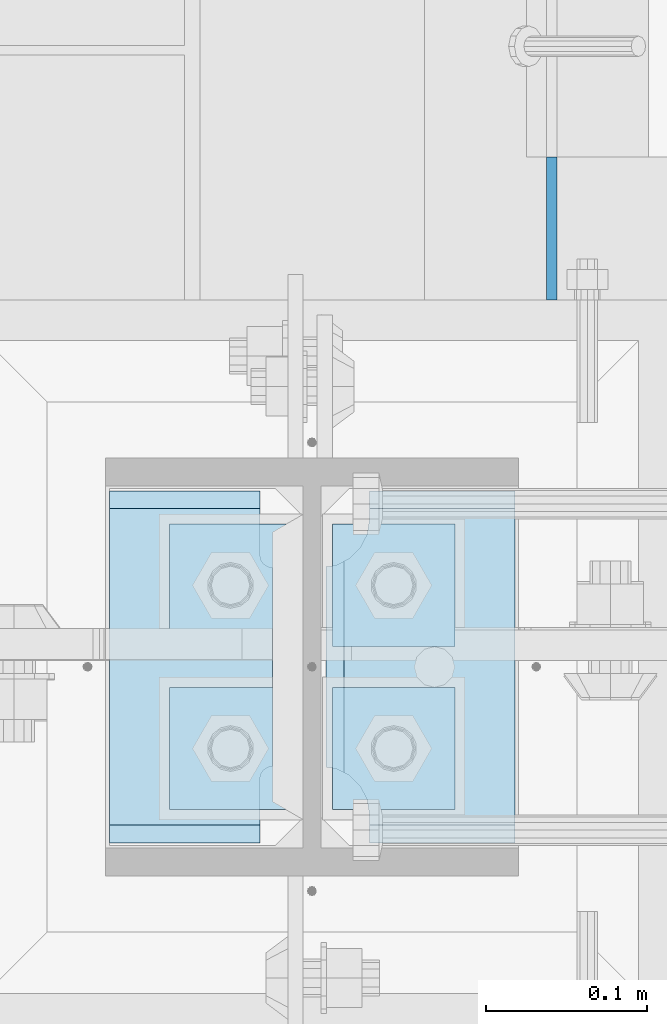
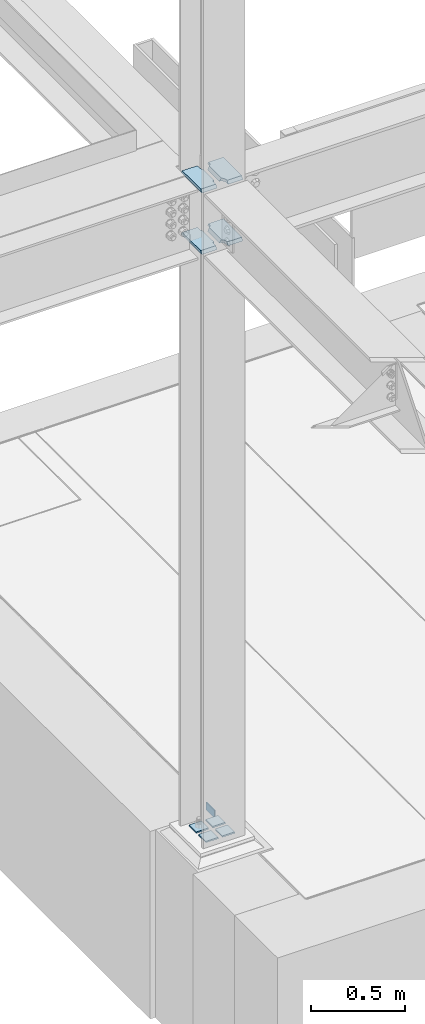
# One storey, part 3058 of 3843: 9 plates, 3 elements without a shape of their own.
"""IFC2X3 building model written with IfcOpenShell, lengths in millimetres."""

from ifc_helpers import new_model, si_unit, frame, origin_with_axes, place, context, subcontext, project, spatial, faceted_brep, material, type_object, element, aggregate, save


model = new_model("IFC2X3")

# Units and contexts
model_context = context("Model", 3, precision=1e-05, world=origin_with_axes())
body_context = subcontext(model_context, "Body", "Model", "MODEL_VIEW")
ifc_project = project(units=[si_unit("LENGTHUNIT", "METRE", prefix="MILLI"), si_unit("AREAUNIT", "SQUARE_METRE"), si_unit("VOLUMEUNIT", "CUBIC_METRE"), si_unit("MASSUNIT", "GRAM", prefix="KILO"), si_unit("TIMEUNIT", "SECOND"), si_unit("PLANEANGLEUNIT", "RADIAN"), si_unit("SOLIDANGLEUNIT", "STERADIAN"), si_unit("THERMODYNAMICTEMPERATUREUNIT", "DEGREE_CELSIUS"), si_unit("LUMINOUSINTENSITYUNIT", "LUMEN")], contexts=[model_context])

# Site, building, storey
site_placement = place(None, origin_with_axes())
site = spatial("IfcSite", under=ifc_project, at=site_placement, CompositionType="ELEMENT")
building_placement = place(site_placement, origin_with_axes())
building = spatial("IfcBuilding", under=site, at=building_placement, Name="Undefined", CompositionType="ELEMENT")
storey_placement = place(building_placement, origin_with_axes())
storey = spatial("IfcBuildingStorey", under=building, at=storey_placement, Name="Undefined", CompositionType="ELEMENT", Elevation=0.0)

# Assembly, plate
assembly_1_placement = place(storey_placement, origin_with_axes())
assembly_1 = element("IfcElementAssembly", 1, at=assembly_1_placement, inside=storey, Name="GRATING", AssemblyPlace="NOTDEFINED", PredefinedType="NOTDEFINED")
ifc_material_1 = material(Name="STEEL/A36")
plate_type_1 = type_object("IfcPlateType", PredefinedType="NOTDEFINED")
plate_1_placement = place(assembly_1_placement, frame((56080.025000002, 15316.2002323447, 30429.2000030518), z_axis=(1.49999978020787e-08, -0.999999999997976, -2.01200000810786e-06), x_axis=(0.0, -2.01200000823323e-06, 0.999999999997976)))
plate_1 = element("IfcPlate", 2, at=plate_1_placement, type_object=plate_type_1, material=ifc_material_1, Name="PLATE", context=body_context, shape_type="Brep", body=[
    faceted_brep([(0.0, -3.17499999999927, 0.0), (0.000179417467734311, -3.17500000026484, 88.9001281746187), (0.000179417467734311, 3.17499999974098, 88.900128174615), (0.0, 3.17499999999927, 0.0), (50.8001812234725, -3.17500000026484, 88.9000671394897), (50.8001812234725, 3.17499999974098, 88.9000671394861), (50.7999954217848, -3.17499999999563, -7.27595761418343e-12), (50.7999954217848, 3.17500000001019, -1.09139364212751e-11)], [[[0, 1, 2, 3]], [[1, 4, 5, 2]], [[4, 6, 7, 5]], [[6, 0, 3, 7]], [[5, 7, 3, 2]], [[6, 4, 1, 0]]]),
])
aggregate(assembly_1, [plate_1])

# Assembly, plates
assembly_2_placement = place(storey_placement, origin_with_axes())
assembly_2 = element("IfcElementAssembly", 3, at=assembly_2_placement, inside=storey, Name="TEMPLATE", AssemblyPlace="NOTDEFINED", PredefinedType="RIGID_FRAME")
ifc_material_2 = material(Name="STEEL/A572-50")
plate_type_2 = type_object("IfcPlateType", PredefinedType="NOTDEFINED")
plate_2_placement = place(assembly_2_placement, frame((55918.1, 14986.0, 30548.2625), z_axis=(-1.0, 0.0, 0.0), x_axis=(0.0, -1.0, 0.0)))
plate_2 = element("IfcPlate", 4, at=plate_2_placement, type_object=plate_type_2, material=ifc_material_2, Name="Washer Plate", context=body_context, shape_type="Brep", body=[
    faceted_brep([(0.0, -4.76249999999709, 0.0), (-3.49245965480804e-10, -4.76249999999709, 76.1999999999462), (-3.49245965480804e-10, 4.76249999999709, 76.1999999999462), (0.0, 4.76249999999709, 0.0), (76.1999893188477, -4.76249999999709, 76.1999969482422), (76.1999893188477, 4.76249999999709, 76.1999969482422), (76.2000000012922, -4.76250000000073, 7.27595761418343e-11), (76.2000000012922, 4.76250000000073, 7.27595761418343e-11)], [[[0, 1, 2, 3]], [[1, 4, 5, 2]], [[4, 6, 7, 5]], [[6, 0, 3, 7]], [[5, 7, 3, 2]], [[6, 4, 1, 0]]]),
])
plate_3_placement = place(assembly_2_placement, frame((56019.7, 14986.0, 30548.2625), z_axis=(-1.0, 0.0, 0.0), x_axis=(0.0, -1.0, 0.0)))
plate_3 = element("IfcPlate", 5, at=plate_3_placement, type_object=plate_type_2, material=ifc_material_2, Name="Washer Plate", context=body_context, shape_type="Brep", body=[
    faceted_brep([(0.0, -4.76249999999709, 0.0), (-3.49245965480804e-10, -4.76249999999709, 76.1999999999462), (-3.49245965480804e-10, 4.76249999999709, 76.1999999999462), (0.0, 4.76249999999709, 0.0), (76.1999893188477, -4.76249999999709, 76.1999969482422), (76.1999893188477, 4.76249999999709, 76.1999969482422), (76.2000000012922, -4.76250000000073, 7.27595761418343e-11), (76.2000000012922, 4.76250000000073, 7.27595761418343e-11)], [[[0, 1, 2, 3]], [[1, 4, 5, 2]], [[4, 6, 7, 5]], [[6, 0, 3, 7]], [[5, 7, 3, 2]], [[6, 4, 1, 0]]]),
])
plate_4_placement = place(assembly_2_placement, frame((55918.1, 15087.6, 30548.2625), z_axis=(-1.0, 0.0, 0.0), x_axis=(0.0, -1.0, 0.0)))
plate_4 = element("IfcPlate", 6, at=plate_4_placement, type_object=plate_type_2, material=ifc_material_2, Name="Washer Plate", context=body_context, shape_type="Brep", body=[
    faceted_brep([(0.0, -4.76249999999709, 0.0), (-3.49245965480804e-10, -4.76249999999709, 76.1999999999462), (-3.49245965480804e-10, 4.76249999999709, 76.1999999999462), (0.0, 4.76249999999709, 0.0), (76.1999893188477, -4.76249999999709, 76.1999969482422), (76.1999893188477, 4.76249999999709, 76.1999969482422), (76.2000000012922, -4.76250000000073, 7.27595761418343e-11), (76.2000000012922, 4.76250000000073, 7.27595761418343e-11)], [[[0, 1, 2, 3]], [[1, 4, 5, 2]], [[4, 6, 7, 5]], [[6, 0, 3, 7]], [[5, 7, 3, 2]], [[6, 4, 1, 0]]]),
])
plate_5_placement = place(assembly_2_placement, frame((56019.7, 15087.6, 30548.2625), z_axis=(-1.0, 0.0, 0.0), x_axis=(0.0, -1.0, 0.0)))
plate_5 = element("IfcPlate", 7, at=plate_5_placement, type_object=plate_type_2, material=ifc_material_2, Name="Washer Plate", context=body_context, shape_type="Brep", body=[
    faceted_brep([(0.0, -4.76249999999709, 0.0), (-3.49245965480804e-10, -4.76249999999709, 76.1999999999462), (-3.49245965480804e-10, 4.76249999999709, 76.1999999999462), (0.0, 4.76249999999709, 0.0), (76.1999893188477, -4.76249999999709, 76.1999969482422), (76.1999893188477, 4.76249999999709, 76.1999969482422), (76.2000000012922, -4.76250000000073, 7.27595761418343e-11), (76.2000000012922, 4.76250000000073, 7.27595761418343e-11)], [[[0, 1, 2, 3]], [[1, 4, 5, 2]], [[4, 6, 7, 5]], [[6, 0, 3, 7]], [[5, 7, 3, 2]], [[6, 4, 1, 0]]]),
])
aggregate(assembly_2, [plate_2, plate_3, plate_4, plate_5])

assembly_3_placement = place(storey_placement, origin_with_axes())
assembly_3 = element("IfcElementAssembly", 8, at=assembly_3_placement, inside=storey, Name="COLUMN", AssemblyPlace="NOTDEFINED", PredefinedType="RIGID_FRAME")
plate_type_3 = type_object("IfcPlateType", PredefinedType="NOTDEFINED")
plate_6_placement = place(assembly_3_placement, frame((56057.00625, 14885.9875, 34401.125), z_axis=(0.0, 1.0, 0.0), x_axis=(-1.0, 0.0, 0.0)))
plate_6 = element("IfcPlate", 9, at=plate_6_placement, type_object=plate_type_3, material=ifc_material_2, Name="PLATE", context=body_context, shape_type="Brep", body=[
    faceted_brep([(106.476727860114, 9.52500000000146, 46.8512444583885), (106.476727860114, 9.52500000000146, 178.573758593369), (111.329276315162, 1.12013952965935, 176.101261660615), (117.47525004769, -9.52500000000146, 175.12783505074), (117.47525004769, -9.52500000000146, 50.2971680010178), (111.329276315162, 1.12013952965935, 49.3237413911429), (0.0, 9.52500000000146, 211.2519778601), (0.0, -9.52500000000146, 222.250500047679), (90.4875011444092, -9.52500000000146, 222.250500047679), (90.4875011444092, 9.52500000000146, 211.2519778601), (90.4875011444092, 9.52500000000146, 14.1740221398904), (90.4875011444092, -9.52500000000146, 3.17549995231093), (0.0, -9.52500000000146, 3.17549995231093), (0.0, 9.52500000000146, 14.1740221398904), (90.4875011444092, -9.52500000000146, 204.787504196167), (90.4875011444092, 9.52500000000146, 204.787504196167), (91.9637589903286, -9.52500000000146, 195.466778985452), (91.9637589903286, 9.52500000000146, 195.466778985452), (96.2480261244273, -9.52500000000146, 187.058431299673), (96.2480261244273, 9.52500000000146, 187.058431299673), (102.920928629384, -9.52500000000146, 180.385528794717), (102.920928629384, 9.52500000000146, 180.385528794717), (111.329276315162, -9.52500000000146, 176.101261660615), (111.329276315162, -9.52500000000146, 49.3237413911429), (102.920928629384, -9.52500000000146, 45.0394742570406), (102.920928629384, 9.52500000000146, 45.0394742570406), (96.2480261244273, -9.52500000000146, 38.3665717520853), (96.2480261244273, 9.52500000000146, 38.3665717520853), (91.9637589903286, -9.52500000000146, 29.9582240663058), (91.9637589903286, 9.52500000000146, 29.9582240663058), (90.4875011444092, -9.52500000000146, 20.6374988555908), (90.4875011444092, 9.52500000000146, 20.6374988555908)], [[[0, 1, 2, 3, 4, 5]], [[6, 7, 8, 9]], [[10, 11, 12, 13]], [[13, 12, 7, 6]], [[14, 15, 9, 8]], [[14, 16, 17, 15]], [[16, 18, 19, 17]], [[18, 20, 21, 19]], [[21, 20, 22, 2, 1]], [[22, 3, 2]], [[23, 5, 4]], [[23, 24, 25, 0, 5]], [[24, 26, 27, 25]], [[26, 28, 29, 27]], [[28, 30, 31, 29]], [[31, 30, 11, 10]], [[25, 27, 29, 31, 10, 13, 6, 9, 15, 17, 19, 21, 1, 0]], [[11, 30, 28, 26, 24, 23, 4, 3, 22, 20, 18, 16, 14, 8, 7, 12]]]),
])
plate_7_placement = place(assembly_3_placement, frame((56057.00625, 14885.9875, 34801.175), z_axis=(0.0, 1.0, 0.0), x_axis=(-1.0, 0.0, 0.0)))
plate_7 = element("IfcPlate", 10, at=plate_7_placement, type_object=plate_type_3, material=ifc_material_2, Name="PLATE", context=body_context, shape_type="Brep", body=[
    faceted_brep([(106.476727860114, 9.52500000000146, 46.8512444583885), (106.476727860114, 9.52500000000146, 178.573758593369), (111.329276315162, 1.12013952965935, 176.101261660615), (117.47525004769, -9.52500000000146, 175.12783505074), (117.47525004769, -9.52500000000146, 50.2971680010178), (111.329276315162, 1.12013952965935, 49.3237413911429), (0.0, 9.52500000000146, 211.2519778601), (0.0, -9.52500000000146, 222.250500047679), (90.4875011444092, -9.52500000000146, 222.250500047679), (90.4875011444092, 9.52500000000146, 211.2519778601), (90.4875011444092, 9.52500000000146, 14.1740221398904), (90.4875011444092, -9.52500000000146, 3.17549995231093), (0.0, -9.52500000000146, 3.17549995231093), (0.0, 9.52500000000146, 14.1740221398904), (90.4875011444092, -9.52500000000146, 204.787504196167), (90.4875011444092, 9.52500000000146, 204.787504196167), (91.9637589903286, -9.52500000000146, 195.466778985452), (91.9637589903286, 9.52500000000146, 195.466778985452), (96.2480261244273, -9.52500000000146, 187.058431299673), (96.2480261244273, 9.52500000000146, 187.058431299673), (102.920928629384, -9.52500000000146, 180.385528794717), (102.920928629384, 9.52500000000146, 180.385528794717), (111.329276315162, -9.52500000000146, 176.101261660615), (111.329276315162, -9.52500000000146, 49.3237413911429), (102.920928629384, -9.52500000000146, 45.0394742570406), (102.920928629384, 9.52500000000146, 45.0394742570406), (96.2480261244273, -9.52500000000146, 38.3665717520853), (96.2480261244273, 9.52500000000146, 38.3665717520853), (91.9637589903286, -9.52500000000146, 29.9582240663058), (91.9637589903286, 9.52500000000146, 29.9582240663058), (90.4875011444092, -9.52500000000146, 20.6374988555908), (90.4875011444092, 9.52500000000146, 20.6374988555908)], [[[0, 1, 2, 3, 4, 5]], [[6, 7, 8, 9]], [[10, 11, 12, 13]], [[13, 12, 7, 6]], [[14, 15, 9, 8]], [[14, 16, 17, 15]], [[16, 18, 19, 17]], [[18, 20, 21, 19]], [[21, 20, 22, 2, 1]], [[22, 3, 2]], [[23, 5, 4]], [[23, 24, 25, 0, 5]], [[24, 26, 27, 25]], [[26, 28, 29, 27]], [[28, 30, 31, 29]], [[31, 30, 11, 10]], [[25, 27, 29, 31, 10, 13, 6, 9, 15, 17, 19, 21, 1, 0]], [[11, 30, 28, 26, 24, 23, 4, 3, 22, 20, 18, 16, 14, 8, 7, 12]]]),
])
plate_type_4 = type_object("IfcPlateType", PredefinedType="NOTDEFINED")
plate_8_placement = place(assembly_3_placement, frame((55804.59375, 15111.4125, 34401.125), z_axis=(0.0, -1.0, 0.0), x_axis=(1.0, 0.0, 0.0)))
plate_8 = element("IfcPlate", 11, at=plate_8_placement, type_object=plate_type_4, material=ifc_material_2, Name="PLATE", context=body_context, shape_type="Brep", body=[
    faceted_brep([(0.0, 9.52500000000146, 211.2519778601), (0.0, -9.52500000000146, 222.250500047679), (93.6624999999985, -9.52500000000146, 222.250500047679), (93.6624999999985, 9.52500000000146, 211.2519778601), (93.6624999999985, 9.52500000000146, 14.1740221398904), (93.6624999999985, -9.52500000000146, 3.17549995231093), (0.0, -9.52500000000146, 3.17549995231093), (0.0, 9.52500000000146, 14.1740221398904), (93.6624999999985, -9.52500000000146, 182.562500762939), (93.6624999999985, 9.52500000000146, 182.562500762939), (94.2667062106921, -9.52500000000146, 179.52495101854), (94.2667062106921, 9.52500000000146, 179.52495101854), (95.9873399243297, -9.52500000000146, 176.94984068727), (95.9873399243297, 9.52500000000146, 176.94984068727), (98.562450255602, -9.52500000000146, 175.22920697363), (98.562450255602, 9.52500000000146, 175.22920697363), (101.599999999999, -9.52500000000146, 174.625000762939), (101.599999999999, 9.52500000000146, 174.625000762939), (101.599999999999, -9.52500000000146, 50.7999992370605), (101.599999999999, 9.52500000000146, 50.7999992370605), (98.562450255602, -9.52500000000146, 50.1957930263688), (98.562450255602, 9.52500000000146, 50.1957930263688), (95.9873399243297, -9.52500000000146, 48.4751593127294), (95.9873399243297, 9.52500000000146, 48.4751593127294), (94.2667062106921, -9.52500000000146, 45.9000489814589), (94.2667062106921, 9.52500000000146, 45.9000489814589), (93.6624999999985, -9.52500000000146, 42.8624992370605), (93.6624999999985, 9.52500000000146, 42.8624992370605)], [[[0, 1, 2, 3]], [[4, 5, 6, 7]], [[7, 6, 1, 0]], [[8, 9, 3, 2]], [[8, 10, 11, 9]], [[10, 12, 13, 11]], [[12, 14, 15, 13]], [[14, 16, 17, 15]], [[16, 18, 19, 17]], [[18, 20, 21, 19]], [[20, 22, 23, 21]], [[22, 24, 25, 23]], [[24, 26, 27, 25]], [[27, 26, 5, 4]], [[9, 11, 13, 15, 17, 19, 21, 23, 25, 27, 4, 7, 0, 3]], [[5, 26, 24, 22, 20, 18, 16, 14, 12, 10, 8, 2, 1, 6]]]),
])
plate_9_placement = place(assembly_3_placement, frame((55804.59375, 15111.4125, 34801.175), z_axis=(0.0, -1.0, 0.0), x_axis=(1.0, 0.0, 0.0)))
plate_9 = element("IfcPlate", 12, at=plate_9_placement, type_object=plate_type_4, material=ifc_material_2, Name="PLATE", context=body_context, shape_type="Brep", body=[
    faceted_brep([(0.0, 9.52500000000146, 211.2519778601), (0.0, -9.52500000000146, 222.250500047679), (93.6624999999985, -9.52500000000146, 222.250500047679), (93.6624999999985, 9.52500000000146, 211.2519778601), (93.6624999999985, 9.52500000000146, 14.1740221398904), (93.6624999999985, -9.52500000000146, 3.17549995231093), (0.0, -9.52500000000146, 3.17549995231093), (0.0, 9.52500000000146, 14.1740221398904), (93.6624999999985, -9.52500000000146, 182.562500762939), (93.6624999999985, 9.52500000000146, 182.562500762939), (94.2667062106921, -9.52500000000146, 179.52495101854), (94.2667062106921, 9.52500000000146, 179.52495101854), (95.9873399243297, -9.52500000000146, 176.94984068727), (95.9873399243297, 9.52500000000146, 176.94984068727), (98.562450255602, -9.52500000000146, 175.22920697363), (98.562450255602, 9.52500000000146, 175.22920697363), (101.599999999999, -9.52500000000146, 174.625000762939), (101.599999999999, 9.52500000000146, 174.625000762939), (101.599999999999, -9.52500000000146, 50.7999992370605), (101.599999999999, 9.52500000000146, 50.7999992370605), (98.562450255602, -9.52500000000146, 50.1957930263688), (98.562450255602, 9.52500000000146, 50.1957930263688), (95.9873399243297, -9.52500000000146, 48.4751593127294), (95.9873399243297, 9.52500000000146, 48.4751593127294), (94.2667062106921, -9.52500000000146, 45.9000489814589), (94.2667062106921, 9.52500000000146, 45.9000489814589), (93.6624999999985, -9.52500000000146, 42.8624992370605), (93.6624999999985, 9.52500000000146, 42.8624992370605)], [[[0, 1, 2, 3]], [[4, 5, 6, 7]], [[7, 6, 1, 0]], [[8, 9, 3, 2]], [[8, 10, 11, 9]], [[10, 12, 13, 11]], [[12, 14, 15, 13]], [[14, 16, 17, 15]], [[16, 18, 19, 17]], [[18, 20, 21, 19]], [[20, 22, 23, 21]], [[22, 24, 25, 23]], [[24, 26, 27, 25]], [[27, 26, 5, 4]], [[9, 11, 13, 15, 17, 19, 21, 23, 25, 27, 4, 7, 0, 3]], [[5, 26, 24, 22, 20, 18, 16, 14, 12, 10, 8, 2, 1, 6]]]),
])
aggregate(assembly_3, [plate_6, plate_7, plate_8, plate_9])

save(model, "model.ifc")
